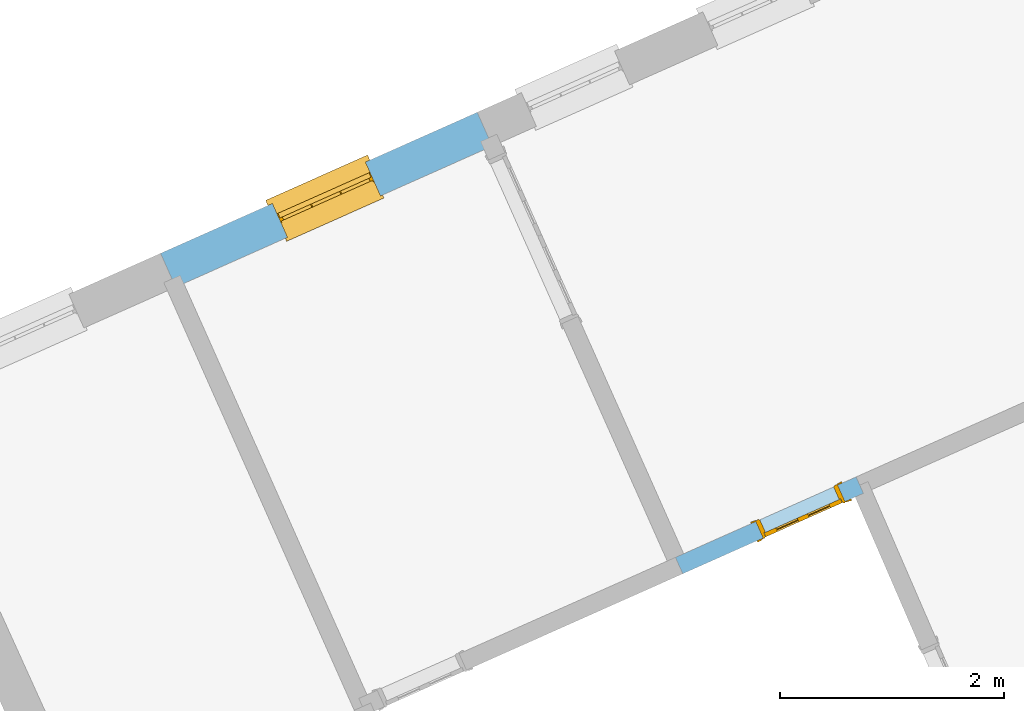
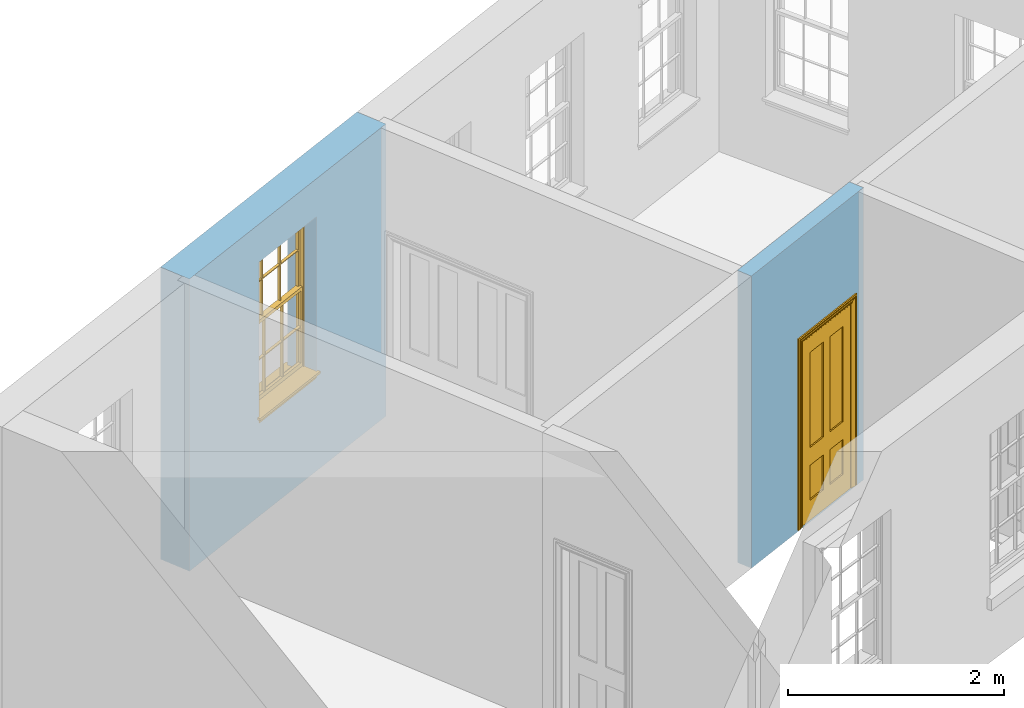
# One storey, part 4 of 8: 1 door, 1 window, 2 openings, plus 2 elements that do not belong to this part.
"""IFC2X3 building model written with IfcOpenShell, lengths in metres."""

from ifc_helpers import new_model, si_unit, frame, origin, place, context, subcontext, project, spatial, polyline, outline, extrude, faceted_brep, material, layer, layer_set, layer_usage, element, fill, save


model = new_model("IFC2X3")

# Units and contexts
model_context = context("Model", 3, world=origin())
body_context = subcontext(model_context, "Body", "Model", "MODEL_VIEW")
ifc_project = project(units=[si_unit("PLANEANGLEUNIT", "RADIAN"), si_unit("MASSUNIT", "GRAM", prefix="KILO"), si_unit("FORCEUNIT", "NEWTON", prefix="KILO"), si_unit("LENGTHUNIT", "METRE")], contexts=[model_context])

# Site, building, storey
site_placement = place(None, origin())
site = spatial("IfcSite", under=ifc_project, at=site_placement, CompositionType="ELEMENT")
building_placement = place(None, origin())
building = spatial("IfcBuilding", under=site, at=building_placement, Name="Building plot-1", CompositionType="ELEMENT")
storey_placement = place(None, frame((0.0, 0.0, 5.15)))
storey = spatial("IfcBuildingStorey", under=building, at=storey_placement, Name="Floor 1", CompositionType="ELEMENT", Elevation=5.15)

# Wall, opening, window
ifc_material_1 = material(Name="Masonry")
ifc_layer_1 = layer(ifc_material_1, 0.33, ventilated=False)
ifc_layer_set_1 = layer_set([ifc_layer_1], Name="My Wall")
ifc_layer_usage_1 = layer_usage(ifc_layer_set_1, "AXIS2", "NEGATIVE", 0.08)
wall_1_placement = place(storey_placement, origin())
wall_1 = element("IfcWallStandardCase", 1, at=wall_1_placement, inside=storey, material=ifc_layer_usage_1, Name="exterior", context=body_context, shape_type="SweptSolid", body=[
    extrude(outline(polyline([(24.443685610287, 48.5400055490315), (24.3094306325007, 48.841461351662), (21.4842375416494, 47.5832462755393), (21.6184925194357, 47.2817904729088), (24.443685610287, 48.5400055490315)])), origin(), (0.0, 0.0, 1.0), 3.3),
])
opening_1_placement = place(storey_placement, frame((0.0, 0.0, 1.05)))
opening_1 = element("IfcOpeningElement", 2, at=opening_1_placement, cuts=wall_1, Name="Opening", ObjectType="Opening", context=body_context, shape_type="SweptSolid", body=[
    extrude(outline(polyline([(23.3124776937322, 48.3974629496394), (22.4811904804179, 48.0272446775619), (22.6154454582042, 47.7257888749314), (23.4467326715186, 48.0960071470089), (23.3124776937322, 48.3974629496394)])), origin(), (0.0, 0.0, 1.0), 1.82),
])
window_placement = place(storey_placement, frame((23.414186010237, 48.169087341586, 1.05), z_axis=(0.0, 0.0, 1.0), x_axis=(-0.831287213314369, -0.370218272077473, 0.0)))
window = element("IfcWindow", 3, at=window_placement, inside=storey, Name="kitchen outside window", OverallHeight=1.82, OverallWidth=0.91, context=body_context, shape_type="Brep", held_by="IfcProductRepresentation", body=[
    faceted_brep([(0.033125, -0.105, 0.975209), (0.01, -0.105, 0.975209), (0.033125, -0.105, 1.376042), (0.876875, -0.105, 0.975209), (0.876875, -0.105, 1.376042), (0.9, -0.105, 0.975209), (0.876875, -0.105, 1.386042), (0.876875, -0.105, 1.786875), (0.9, -0.105, 1.81), (0.033125, -0.105, 1.786875), (0.033125, -0.105, 1.386042), (0.01, -0.105, 1.81), (0.876875, -0.135, 1.376042), (0.876875, -0.135, 0.975209), (0.9, -0.135, 0.937083), (0.033125, -0.135, 1.786875), (0.01, -0.135, 1.81), (0.033125, -0.135, 1.386042), (0.01, -0.135, 0.937083), (0.033125, -0.135, 0.975209), (0.033125, -0.135, 1.376042), (0.876875, -0.135, 1.786875), (0.876875, -0.135, 1.386042), (0.9, -0.135, 1.81), (0.033125, -0.105, 0.937083), (0.01, -0.105, 0.937083), (0.033125, -0.105, 0.53625), (0.876875, -0.105, 0.937083), (0.876875, -0.105, 0.53625), (0.9, -0.105, 0.937083), (0.876875, -0.105, 0.52625), (0.876875, -0.105, 0.125417), (0.9, -0.105, 0.077167), (0.033125, -0.105, 0.125417), (0.033125, -0.105, 0.52625), (0.01, -0.105, 0.077167), (-0.0425, -0.25, 0.01), (-0.0425, -0.3, 0.001667), (0.0, -0.25, 0.01), (0.9525, -0.25, 0.01), (0.91, -0.25, 0.01), (0.9525, -0.3, 0.001667), (-0.02, 0.08, 0.077167), (0.0, 0.08, 0.077167), (-0.02, 0.11, 0.077167), (0.0, -0.06, 0.077167), (0.01, -0.06, 0.077167), (0.91, -0.06, 0.077167), (0.91, 0.08, 0.077167), (0.9, -0.06, 0.077167), (0.93, 0.08, 0.077167), (0.93, 0.11, 0.077167), (0.01, -0.075, 0.975209), (0.9, -0.075, 0.975209), (0.876875, -0.075, 0.125417), (0.876875, -0.075, 0.52625), (0.9, -0.075, 0.077167), (0.876875, -0.075, 0.53625), (0.876875, -0.075, 0.937083), (0.033125, -0.075, 0.125417), (0.01, -0.075, 0.077167), (0.033125, -0.075, 0.52625), (0.033125, -0.075, 0.937083), (0.033125, -0.075, 0.53625), (-0.02, 0.08, 0.052167), (-0.02, 0.11, 0.052167), (0.93, 0.11, 0.052167), (0.93, 0.08, 0.052167), (0.91, 0.08, 0.052167), (0.0, 0.08, 0.052167), (0.91, -0.15, 0.026667), (0.0, -0.15, 0.026667), (-0.0425, -0.3, -0.123333), (0.9525, -0.3, -0.123333), (-0.0425, -0.25, -0.123333), (0.9525, -0.25, -0.123333), (0.01, -0.06, 1.81), (0.9, -0.06, 1.81), (0.0, -0.06, 1.82), (0.91, -0.06, 1.82), (0.01, -0.15, 0.077167), (0.9, -0.15, 0.077167), (0.592292, -0.105, 0.125417), (0.592292, -0.075, 0.125417), (0.317708, -0.075, 0.125417), (0.317708, -0.105, 0.125417), (0.592292, -0.105, 0.53625), (0.317708, -0.105, 0.53625), (0.317708, -0.105, 0.52625), (0.592292, -0.105, 0.52625), (0.592292, -0.075, 0.53625), (0.317708, -0.075, 0.53625), (0.592292, -0.135, 1.386042), (0.592292, -0.105, 1.386042), (0.317708, -0.105, 1.386042), (0.317708, -0.135, 1.386042), (0.317708, -0.135, 1.376042), (0.592292, -0.135, 1.376042), (0.317708, -0.105, 1.376042), (0.592292, -0.105, 1.376042), (0.602292, -0.135, 1.376042), (0.592292, -0.135, 0.975209), (0.602292, -0.135, 0.975209), (0.602292, -0.105, 0.975209), (0.592292, -0.105, 0.975209), (0.602292, -0.105, 1.376042), (0.602292, -0.075, 0.53625), (0.602292, -0.105, 0.53625), (0.317708, -0.075, 0.52625), (0.307708, -0.075, 0.125417), (0.307708, -0.075, 0.52625), (0.602292, -0.075, 0.52625), (0.602292, -0.075, 0.125417), (0.592292, -0.075, 0.52625), (0.307708, -0.075, 0.53625), (0.317708, -0.075, 0.937083), (0.307708, -0.075, 0.937083), (0.602292, -0.075, 0.937083), (0.592292, -0.075, 0.937083), (0.307708, -0.105, 0.52625), (0.307708, -0.105, 0.125417), (0.307708, -0.105, 0.53625), (0.307708, -0.105, 0.937083), (0.592292, -0.105, 0.937083), (0.317708, -0.105, 0.937083), (0.602292, -0.105, 0.937083), (0.602292, -0.105, 0.52625), (0.602292, -0.105, 0.125417), (0.307708, -0.135, 1.386042), (0.307708, -0.135, 1.376042), (0.307708, -0.135, 0.975209), (0.317708, -0.135, 0.975209), (0.317708, -0.135, 1.786875), (0.307708, -0.135, 1.786875), (0.602292, -0.135, 1.786875), (0.592292, -0.135, 1.786875), (0.602292, -0.135, 1.386042), (0.602292, -0.105, 1.386042), (0.307708, -0.105, 1.386042), (0.307708, -0.105, 1.786875), (0.317708, -0.105, 1.786875), (0.592292, -0.105, 1.786875), (0.602292, -0.105, 1.786875), (0.307708, -0.105, 1.376042), (0.317708, -0.105, 0.975209), (0.307708, -0.105, 0.975209), (0.91, -0.15, 1.82), (0.9, -0.15, 1.81), (0.01, -0.15, 1.81), (0.0, -0.15, 1.82), (0.91, -0.25, 0.0), (0.0, -0.25, 0.0), (0.91, 0.08, 0.0), (0.0, 0.08, 0.0)], [[[0, 1, 2]], [[3, 4, 5]], [[6, 7, 8]], [[9, 10, 11]], [[12, 13, 14]], [[15, 16, 17]], [[18, 19, 20]], [[21, 22, 23]], [[24, 25, 26]], [[27, 28, 29]], [[30, 31, 32]], [[33, 34, 35]], [[14, 27, 29]], [[25, 24, 18]], [[36, 37, 38]], [[39, 40, 41]], [[42, 43, 44]], [[45, 46, 43]], [[47, 48, 49]], [[50, 51, 48]], [[1, 0, 52]], [[5, 53, 3]], [[54, 55, 56]], [[57, 58, 53]], [[59, 60, 61]], [[62, 63, 52]], [[48, 43, 46, 49]], [[51, 44, 43, 48]], [[64, 42, 44, 65]], [[65, 44, 51, 66]], [[66, 51, 50, 67]], [[65, 66, 68, 69]], [[60, 56, 49, 46]], [[70, 71, 38, 40]], [[37, 41, 40, 38]], [[37, 72, 73, 41]], [[74, 75, 73, 72]], [[8, 11, 76, 77]], [[76, 78, 79, 77]], [[32, 35, 80, 81]], [[81, 80, 71, 70]], [[82, 83, 84, 85]], [[86, 87, 88, 89]], [[86, 90, 91, 87]], [[92, 93, 94, 95]], [[92, 95, 96, 97]], [[96, 98, 99, 97]], [[100, 97, 101, 102]], [[103, 104, 99, 105]], [[97, 99, 104, 101]], [[102, 103, 105, 100]], [[28, 57, 106, 107]], [[108, 84, 109, 110]], [[111, 112, 83, 113]], [[114, 110, 61, 63]], [[90, 113, 108, 91]], [[115, 91, 114, 116]], [[117, 106, 90, 118]], [[111, 106, 57, 55]], [[119, 110, 109, 120]], [[34, 61, 110, 119]], [[89, 113, 83, 82]], [[88, 108, 113, 89]], [[85, 84, 108, 88]], [[121, 114, 63, 26]], [[122, 116, 114, 121]], [[123, 118, 90, 86]], [[87, 91, 115, 124]], [[107, 106, 117, 125]], [[126, 111, 55, 30]], [[127, 112, 111, 126]], [[126, 30, 28, 107]], [[88, 119, 120, 85]], [[126, 89, 82, 127]], [[125, 123, 86, 107]], [[121, 26, 34, 119]], [[124, 122, 121, 87]], [[128, 17, 20, 129]], [[96, 129, 130, 131]], [[132, 133, 128, 95]], [[134, 135, 92, 136]], [[100, 12, 22, 136]], [[137, 6, 4, 105]], [[94, 138, 139, 140]], [[137, 93, 141, 142]], [[99, 98, 94, 93]], [[143, 2, 10, 138]], [[144, 145, 143, 98]], [[129, 143, 145, 130]], [[20, 2, 143, 129]], [[131, 144, 98, 96]], [[128, 138, 10, 17]], [[133, 139, 138, 128]], [[135, 141, 93, 92]], [[95, 94, 140, 132]], [[22, 6, 137, 136]], [[136, 137, 142, 134]], [[100, 105, 4, 12]], [[107, 86, 89, 126]], [[106, 111, 113, 90]], [[91, 108, 110, 114]], [[87, 121, 119, 88]], [[97, 100, 136, 92]], [[129, 96, 95, 128]], [[98, 143, 138, 94]], [[105, 99, 93, 137]], [[131, 101, 104, 144]], [[124, 115, 118, 123]], [[132, 140, 141, 135]], [[120, 109, 59, 33]], [[15, 9, 139, 133]], [[134, 142, 7, 21]], [[31, 54, 112, 127]], [[36, 74, 72, 37]], [[39, 41, 73, 75]], [[18, 14, 101, 131]], [[23, 16, 132, 135]], [[83, 56, 60, 84]], [[52, 53, 118, 115]], [[53, 52, 144, 104]], [[11, 8, 141, 140]], [[14, 18, 124, 123]], [[2, 1, 11, 10]], [[8, 5, 4, 6]], [[57, 53, 56, 55]], [[60, 52, 63, 61]], [[26, 25, 35, 34]], [[32, 29, 28, 30]], [[14, 23, 22, 12]], [[18, 20, 17, 16]], [[19, 0, 2, 20]], [[17, 10, 9, 15]], [[12, 4, 3, 13]], [[21, 7, 6, 22]], [[27, 58, 57, 28]], [[30, 55, 54, 31]], [[33, 59, 61, 34]], [[26, 63, 62, 24]], [[5, 8, 77, 53]], [[76, 11, 1, 52]], [[46, 45, 78, 76]], [[49, 77, 79, 47]], [[70, 146, 147, 81]], [[71, 80, 148, 149]], [[19, 130, 145, 0]], [[102, 13, 3, 103]], [[116, 122, 24, 62]], [[29, 32, 81, 14]], [[80, 35, 25, 18]], [[60, 46, 76, 52]], [[77, 49, 56, 53]], [[23, 14, 81, 147]], [[16, 148, 80, 18]], [[35, 85, 120]], [[120, 33, 35]], [[127, 82, 32]], [[32, 31, 127]], [[32, 82, 85, 35]], [[102, 101, 14]], [[14, 13, 102]], [[18, 131, 130]], [[130, 19, 18]], [[134, 21, 23]], [[23, 135, 134]], [[16, 15, 133]], [[133, 132, 16]], [[11, 140, 139]], [[139, 9, 11]], [[142, 141, 8]], [[8, 7, 142]], [[23, 147, 148, 16]], [[146, 149, 148, 147]], [[52, 115, 116]], [[116, 62, 52]], [[118, 53, 117]], [[58, 117, 53]], [[27, 125, 117, 58]], [[56, 83, 112]], [[112, 54, 56]], [[109, 84, 60]], [[60, 59, 109]], [[125, 27, 14]], [[14, 123, 125]], [[122, 124, 18]], [[18, 24, 122]], [[145, 144, 52]], [[52, 0, 145]], [[103, 3, 53]], [[53, 104, 103]], [[79, 78, 149, 146]], [[78, 45, 71, 149]], [[146, 70, 47, 79]], [[150, 75, 74, 151]], [[68, 66, 67]], [[48, 68, 67, 50]], [[69, 64, 65]], [[42, 64, 69, 43]], [[69, 68, 152, 153]], [[70, 68, 48, 47]], [[150, 152, 68, 70]], [[43, 69, 71, 45]], [[69, 153, 151, 71]], [[152, 150, 151, 153]], [[38, 151, 74, 36]], [[71, 151, 38]], [[39, 75, 150, 40]], [[40, 150, 70]]]),
])
fill(opening_1, window)

# Wall, opening, door
ifc_material_2 = material(Name="Masonry")
ifc_layer_2 = layer(ifc_material_2, 0.16, ventilated=False)
ifc_layer_set_2 = layer_set([ifc_layer_2], Name="My Wall")
ifc_layer_usage_2 = layer_usage(ifc_layer_set_2, "AXIS2", "NEGATIVE", 0.08)
wall_2_placement = place(storey_placement, origin())
wall_2 = element("IfcWallStandardCase", 4, at=wall_2_placement, inside=storey, material=ifc_layer_usage_2, Name="interior", context=body_context, shape_type="SweptSolid", body=[
    extrude(outline(polyline([(27.754775965969, 45.4421453121994), (27.689682643406, 45.5883057013536), (26.0779204235422, 44.8704986492535), (26.1430137461052, 44.7243382600993), (27.754775965969, 45.4421453121994)])), origin(), (0.0, 0.0, 1.0), 3.3),
])
opening_2_placement = place(storey_placement, frame((0.0, 0.0, 0.0199999999999996)))
opening_2 = element("IfcOpeningElement", 5, at=opening_2_placement, cuts=wall_2, Name="Opening", ObjectType="Opening", context=body_context, shape_type="SweptSolid", body=[
    extrude(outline(polyline([(27.5252522056075, 45.5150757134701), (26.7944502598366, 45.1896091006548), (26.8595435823997, 45.0434487115006), (27.5903455281706, 45.368915324316), (27.5252522056075, 45.5150757134701)])), origin(), (0.0, 0.0, 1.0), 2.1),
])
door_placement = place(storey_placement, frame((27.5577988668891, 45.4419955188931, 0.0199999999999996), z_axis=(0.0, 0.0, 1.0), x_axis=(-0.730801945770882, -0.325466612815347, 0.0)))
door = element("IfcDoor", 6, at=door_placement, inside=storey, Name="living inside door", OverallHeight=2.1, OverallWidth=0.8, context=body_context, shape_type="Brep", held_by="IfcProductRepresentation", body=[
    faceted_brep([(0.773, 0.08, 1.895), (0.66, 0.08, 1.895), (0.66, 0.08, 2.073), (0.773, 0.08, 2.073), (0.773, 0.08, 0.82), (0.66, 0.08, 0.82), (0.45, 0.08, 1.895), (0.45, 0.08, 2.073), (0.773, 0.08, 0.62), (0.66, 0.08, 0.62), (0.66, 0.065, 0.82), (0.66, 0.065, 1.895), (0.45, 0.065, 1.895), (0.35, 0.08, 1.895), (0.35, 0.08, 2.073), (0.773, 0.08, 0.225), (0.66, 0.08, 0.225), (0.45, 0.08, 0.62), (0.45, 0.08, 0.82), (0.45, 0.065, 0.82), (0.35, 0.08, 0.82), (0.14, 0.08, 2.073), (0.14, 0.08, 1.895), (0.773, 0.08, 0.0), (0.66, 0.08, 0.0), (0.66, 0.065, 0.225), (0.66, 0.065, 0.62), (0.45, 0.065, 0.62), (0.35, 0.08, 0.62), (0.35, 0.065, 0.82), (0.35, 0.065, 1.895), (0.14, 0.065, 1.895), (0.027, 0.08, 2.073), (0.027, 0.08, 1.895), (0.773, 0.042, 0.0), (0.66, 0.042, 0.0), (0.45, 0.08, 0.0), (0.45, 0.08, 0.225), (0.45, 0.065, 0.225), (0.35, 0.08, 0.225), (0.14, 0.08, 0.82), (0.14, 0.08, 0.62), (0.14, 0.065, 0.82), (0.027, 0.08, 0.82), (0.773, 0.042, 0.225), (0.66, 0.042, 0.225), (0.45, 0.042, 0.0), (0.35, 0.08, 0.0), (0.35, 0.065, 0.225), (0.35, 0.065, 0.62), (0.14, 0.065, 0.62), (0.027, 0.08, 0.62), (0.773, 0.042, 0.62), (0.66, 0.042, 0.62), (0.45, 0.042, 0.225), (0.35, 0.042, 0.0), (0.14, 0.08, 0.225), (0.14, 0.08, 0.0), (0.14, 0.065, 0.225), (0.027, 0.08, 0.225), (0.773, 0.042, 0.82), (0.66, 0.042, 0.82), (0.66, 0.057, 0.62), (0.66, 0.057, 0.225), (0.45, 0.057, 0.225), (0.35, 0.042, 0.225), (0.14, 0.042, 0.0), (0.027, 0.08, 0.0), (0.773, 0.042, 1.895), (0.66, 0.042, 1.895), (0.45, 0.042, 0.62), (0.45, 0.042, 0.82), (0.45, 0.057, 0.62), (0.35, 0.042, 0.62), (0.14, 0.042, 0.225), (0.027, 0.042, 0.0), (0.773, 0.042, 2.073), (0.66, 0.042, 2.073), (0.66, 0.057, 1.895), (0.66, 0.057, 0.82), (0.45, 0.057, 0.82), (0.35, 0.042, 0.82), (0.35, 0.057, 0.62), (0.35, 0.057, 0.225), (0.14, 0.057, 0.225), (0.027, 0.042, 0.225), (0.45, 0.042, 1.895), (0.45, 0.042, 2.073), (0.45, 0.057, 1.895), (0.35, 0.042, 1.895), (0.14, 0.042, 0.82), (0.14, 0.042, 0.62), (0.14, 0.057, 0.62), (0.027, 0.042, 0.62), (0.35, 0.042, 2.073), (0.35, 0.057, 1.895), (0.35, 0.057, 0.82), (0.14, 0.057, 0.82), (0.027, 0.042, 0.82), (0.14, 0.042, 2.073), (0.14, 0.042, 1.895), (0.14, 0.057, 1.895), (0.027, 0.042, 1.895), (0.027, 0.042, 2.073), (0.02, 0.085, 0.0), (0.005, 0.09, 0.0), (0.005, 0.09, 2.095), (0.02, 0.085, 2.08), (0.02, 0.08, 0.0), (0.0, 0.085, 0.0), (0.0, 0.085, 2.1), (0.795, 0.09, 2.095), (0.78, 0.085, 2.08), (0.02, 0.08, 2.08), (0.0, 0.08, 0.0), (-0.032, 0.095, 0.0), (-0.032, 0.095, 2.132), (0.8, 0.085, 2.1), (0.795, 0.09, 0.0), (0.78, 0.085, 0.0), (0.78, 0.08, 2.08), (0.04, 0.04, 0.0), (0.025, 0.04, 0.0), (0.025, 0.04, 2.075), (0.04, 0.04, 2.06), (-0.04, 0.09, 0.0), (-0.04, 0.09, 2.14), (0.832, 0.095, 2.132), (0.8, 0.085, 0.0), (0.78, 0.08, 0.0), (0.8, 0.08, 0.0), (0.86, 0.08, 0.0), (0.86, 0.08, 2.16), (0.8, 0.08, 2.1), (-0.06, 0.08, 2.16), (0.0, 0.08, 2.1), (-0.06, 0.08, 0.0), (-0.04, 0.095, 0.0), (-0.04, 0.095, 2.14), (0.84, 0.09, 2.14), (0.832, 0.095, 0.0), (0.84, 0.09, 0.0), (0.86, 0.095, 0.0), (0.86, 0.095, 2.16), (-0.06, 0.095, 2.16), (-0.06, 0.095, 0.0), (0.84, 0.095, 0.0), (0.84, 0.095, 2.14), (-0.025, -0.095, 0.0), (-0.025, -0.09, 0.0), (-0.025, -0.09, 2.125), (-0.025, -0.095, 2.125), (-0.017, -0.095, 0.0), (-0.017, -0.095, 2.117), (0.825, -0.09, 2.125), (0.825, -0.095, 2.125), (0.825, -0.095, 0.0), (0.845, -0.095, 0.0), (-0.045, -0.095, 2.145), (-0.045, -0.095, 0.0), (0.845, -0.095, 2.145), (0.015, -0.085, 0.0), (0.015, -0.085, 2.085), (0.817, -0.095, 2.117), (0.825, -0.09, 0.0), (0.845, -0.08, 0.0), (0.845, -0.08, 2.145), (-0.045, -0.08, 2.145), (-0.045, -0.08, 0.0), (0.02, -0.09, 0.0), (0.02, -0.09, 2.08), (0.785, -0.085, 2.085), (0.817, -0.095, 0.0), (0.8, -0.08, 0.0), (0.8, -0.08, 2.1), (0.0, -0.08, 2.1), (0.0, -0.08, 0.0), (0.035, -0.085, 0.0), (0.035, -0.085, 2.065), (0.78, -0.09, 2.08), (0.785, -0.085, 0.0), (0.775, 0.04, 2.075), (0.76, 0.04, 2.06), (0.035, -0.08, 2.065), (0.035, -0.08, 0.0), (0.765, -0.085, 2.065), (0.78, -0.09, 0.0), (0.765, -0.08, 0.0), (0.765, -0.08, 2.065), (0.765, -0.085, 0.0), (0.04, -0.08, 2.06), (0.04, -0.08, 0.0), (0.76, -0.08, 2.06), (0.76, -0.08, 0.0), (0.76, 0.04, 0.0), (0.775, 0.04, 0.0), (0.025, 0.08, 0.0), (0.025, 0.08, 2.075), (0.775, 0.08, 0.0), (0.775, 0.08, 2.075)], [[[0, 1, 2, 3]], [[1, 0, 4, 5]], [[1, 6, 7, 2]], [[8, 9, 5, 4]], [[1, 5, 10, 11]], [[6, 1, 11, 12]], [[6, 13, 14, 7]], [[15, 16, 9, 8]], [[9, 17, 18, 5]], [[5, 18, 19, 10]], [[10, 19, 12, 11]], [[18, 6, 12, 19]], [[18, 20, 13, 6]], [[21, 14, 13, 22]], [[23, 24, 16, 15]], [[9, 16, 25, 26]], [[17, 9, 26, 27]], [[17, 28, 20, 18]], [[13, 20, 29, 30]], [[22, 13, 30, 31]], [[32, 21, 22, 33]], [[34, 35, 24, 23]], [[24, 36, 37, 16]], [[16, 37, 38, 25]], [[25, 38, 27, 26]], [[37, 17, 27, 38]], [[37, 39, 28, 17]], [[40, 20, 28, 41]], [[20, 40, 42, 29]], [[31, 30, 29, 42]], [[40, 22, 31, 42]], [[33, 22, 40, 43]], [[35, 34, 44, 45]], [[35, 46, 36, 24]], [[36, 47, 39, 37]], [[28, 39, 48, 49]], [[41, 28, 49, 50]], [[43, 40, 41, 51]], [[45, 44, 52, 53]], [[46, 35, 45, 54]], [[46, 55, 47, 36]], [[56, 39, 47, 57]], [[39, 56, 58, 48]], [[50, 49, 48, 58]], [[56, 41, 50, 58]], [[51, 41, 56, 59]], [[53, 52, 60, 61]], [[45, 53, 62, 63]], [[54, 45, 63, 64]], [[55, 46, 54, 65]], [[55, 66, 57, 47]], [[59, 56, 57, 67]], [[61, 60, 68, 69]], [[70, 53, 61, 71]], [[53, 70, 72, 62]], [[72, 64, 63, 62]], [[70, 54, 64, 72]], [[65, 54, 70, 73]], [[65, 74, 66, 55]], [[67, 57, 66, 75]], [[69, 68, 76, 77]], [[61, 69, 78, 79]], [[71, 61, 79, 80]], [[73, 70, 71, 81]], [[65, 73, 82, 83]], [[74, 65, 83, 84]], [[74, 85, 75, 66]], [[86, 69, 77, 87]], [[69, 86, 88, 78]], [[88, 80, 79, 78]], [[86, 71, 80, 88]], [[81, 71, 86, 89]], [[73, 81, 90, 91]], [[73, 91, 92, 82]], [[83, 82, 92, 84]], [[91, 74, 84, 92]], [[91, 93, 85, 74]], [[89, 86, 87, 94]], [[81, 89, 95, 96]], [[90, 81, 96, 97]], [[90, 98, 93, 91]], [[94, 99, 100, 89]], [[89, 100, 101, 95]], [[101, 97, 96, 95]], [[100, 90, 97, 101]], [[100, 102, 98, 90]], [[99, 103, 102, 100]], [[32, 103, 99, 21]], [[102, 103, 32, 33]], [[98, 102, 33, 43]], [[21, 99, 94, 14]], [[94, 87, 7, 14]], [[7, 87, 77, 2]], [[76, 3, 2, 77]], [[43, 51, 93, 98]], [[51, 59, 85, 93]], [[67, 75, 85, 59]], [[34, 23, 15, 44]], [[44, 15, 8, 52]], [[52, 8, 4, 60]], [[0, 68, 60, 4]], [[0, 3, 76, 68]], [[104, 105, 106, 107]], [[104, 108, 109, 105]], [[105, 109, 110, 106]], [[107, 106, 111, 112]], [[107, 113, 108, 104]], [[114, 109, 108]], [[109, 115, 116, 110]], [[106, 110, 117, 111]], [[112, 111, 118, 119]], [[113, 107, 112, 120]], [[121, 122, 123, 124]], [[115, 109, 114, 125]], [[115, 125, 126, 116]], [[110, 116, 127, 117]], [[111, 117, 128, 118]], [[118, 128, 129, 119]], [[120, 112, 119, 129]], [[130, 129, 128]], [[130, 131, 132, 133]], [[133, 132, 134, 135]], [[135, 134, 136, 114]], [[136, 125, 114]], [[125, 137, 138, 126]], [[116, 126, 139, 127]], [[117, 127, 140, 128]], [[141, 130, 128, 140]], [[131, 130, 141]], [[131, 142, 143, 132]], [[132, 143, 144, 134]], [[134, 144, 145, 136]], [[137, 125, 136, 145]], [[143, 142, 146]], [[143, 146, 147]], [[137, 145, 144]], [[143, 147, 138]], [[138, 137, 144]], [[143, 138, 144]], [[126, 138, 147, 139]], [[127, 139, 141, 140]], [[142, 131, 141, 146]], [[139, 147, 146, 141]], [[148, 149, 150, 151]], [[149, 152, 153, 150]], [[151, 150, 154, 155]], [[155, 156, 157]], [[158, 159, 148]], [[158, 148, 151]], [[155, 157, 160]], [[158, 151, 155]], [[155, 160, 158]], [[152, 161, 162, 153]], [[150, 153, 163, 154]], [[155, 154, 164, 156]], [[156, 164, 165, 157]], [[157, 165, 166, 160]], [[160, 166, 167, 158]], [[158, 167, 168, 159]], [[161, 169, 170, 162]], [[153, 162, 171, 163]], [[154, 163, 172, 164]], [[165, 164, 173]], [[165, 173, 174, 166]], [[166, 174, 175, 167]], [[167, 175, 176, 168]], [[169, 177, 178, 170]], [[162, 170, 179, 171]], [[163, 171, 180, 172]], [[172, 180, 173, 164]], [[124, 123, 181, 182]], [[183, 178, 177, 184]], [[170, 178, 185, 179]], [[171, 179, 186, 180]], [[187, 173, 180]], [[185, 188, 187, 189]], [[188, 185, 178, 183]], [[179, 185, 189, 186]], [[189, 187, 180, 186]], [[190, 183, 184, 191]], [[192, 188, 183, 190]], [[191, 184, 122, 121]], [[124, 190, 191, 121]], [[193, 187, 188, 192]], [[182, 192, 190, 124]], [[184, 176, 122]], [[194, 195, 187, 193]], [[192, 182, 194, 193]], [[161, 176, 184]], [[114, 108, 122, 176]], [[173, 187, 195]], [[152, 149, 176, 161]], [[169, 161, 184, 177]], [[196, 122, 108]], [[176, 175, 135, 114]], [[173, 195, 129, 130]], [[176, 149, 168]], [[123, 122, 196, 197]], [[196, 108, 113, 197]], [[175, 174, 133, 135]], [[198, 129, 195]], [[133, 174, 173, 130]], [[159, 168, 149, 148]], [[181, 123, 197, 199]], [[197, 113, 120, 199]], [[199, 120, 129, 198]], [[195, 181, 199, 198]], [[195, 194, 182, 181]]]),
])
fill(opening_2, door)

save(model, "model.ifc")
